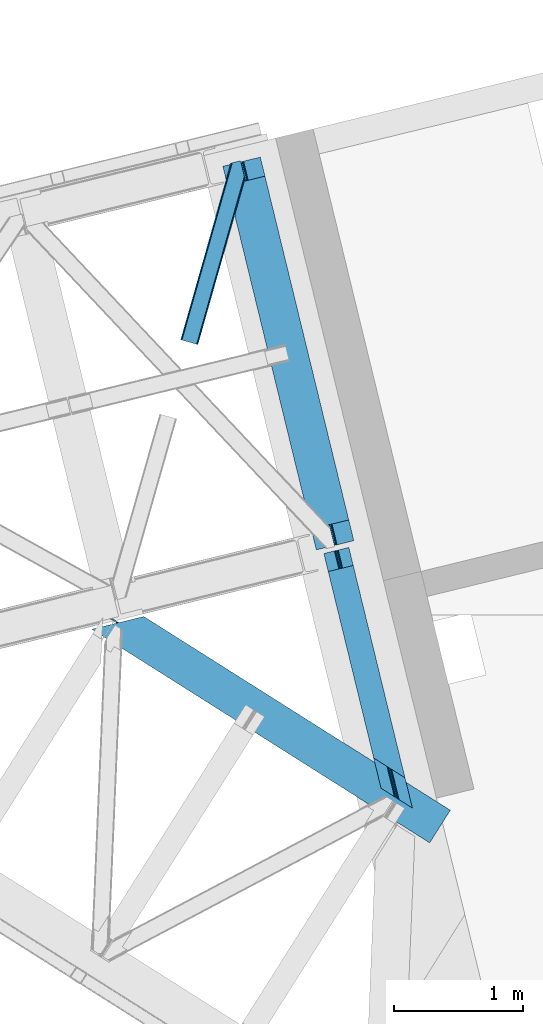
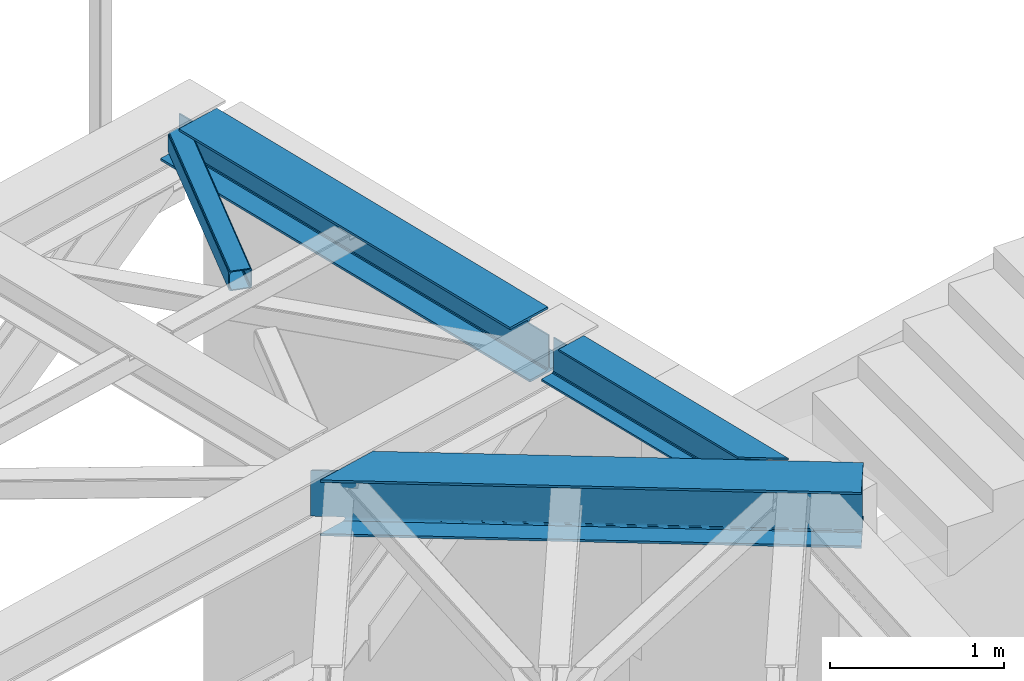
# One storey, part 62 of 67: 3 beams, 1 member.
"""IFC4 building model written with IfcOpenShell, lengths in millimetres."""

from ifc_helpers import new_model, entity, si_unit, converted_unit, derived_unit, direction, frame, origin, place, context, subcontext, project, spatial, triangles, polygons, material, type_object, element, save


model = new_model("IFC4")

# Units and contexts
model_context = context("Model", 3, precision=0.01, world=origin(), true_north=direction((6.12303176911189e-17, 1.0)))
plan_context = context("Plan", 3, precision=0.01, world=origin(), true_north=direction((6.12303176911189e-17, 1.0)))
body_context = subcontext(model_context, "Body", "Model", "MODEL_VIEW")
ifc_project = project(units=[si_unit("LENGTHUNIT", "METRE", prefix="MILLI"), si_unit("AREAUNIT", "SQUARE_METRE"), si_unit("VOLUMEUNIT", "CUBIC_METRE"), converted_unit("PLANEANGLEUNIT", "DEGREE", entity("IfcRatioMeasure", 0.0174532925199433), si_unit("PLANEANGLEUNIT", "RADIAN"), dimensions=[0, 0, 0, 0, 0, 0, 0]), si_unit("MASSUNIT", "GRAM", prefix="KILO"), derived_unit("MASSDENSITYUNIT", [(si_unit("MASSUNIT", "GRAM", prefix="KILO"), 1), (si_unit("LENGTHUNIT", "METRE"), -3)]), derived_unit("MOMENTOFINERTIAUNIT", [(si_unit("LENGTHUNIT", "METRE"), 4)]), si_unit("TIMEUNIT", "SECOND"), si_unit("FREQUENCYUNIT", "HERTZ"), si_unit("THERMODYNAMICTEMPERATUREUNIT", "DEGREE_CELSIUS"), derived_unit("THERMALTRANSMITTANCEUNIT", [(si_unit("MASSUNIT", "GRAM", prefix="KILO"), 1), (si_unit("THERMODYNAMICTEMPERATUREUNIT", "KELVIN"), -1), (si_unit("TIMEUNIT", "SECOND"), -3)]), derived_unit("VOLUMETRICFLOWRATEUNIT", [(si_unit("LENGTHUNIT", "METRE"), 3), (si_unit("TIMEUNIT", "SECOND"), -1)]), derived_unit("MASSFLOWRATEUNIT", [(si_unit("MASSUNIT", "GRAM", prefix="KILO"), 1), (si_unit("TIMEUNIT", "SECOND"), -1)]), derived_unit("ROTATIONALFREQUENCYUNIT", [(si_unit("TIMEUNIT", "SECOND"), -1)]), si_unit("ELECTRICCURRENTUNIT", "AMPERE"), si_unit("ELECTRICVOLTAGEUNIT", "VOLT"), si_unit("POWERUNIT", "WATT"), si_unit("FORCEUNIT", "NEWTON", prefix="KILO"), si_unit("ILLUMINANCEUNIT", "LUX"), si_unit("LUMINOUSFLUXUNIT", "LUMEN"), si_unit("LUMINOUSINTENSITYUNIT", "CANDELA"), derived_unit("USERDEFINED", [(si_unit("MASSUNIT", "GRAM", prefix="KILO"), -1), (si_unit("LENGTHUNIT", "METRE"), -2), (si_unit("TIMEUNIT", "SECOND"), 3), (si_unit("LUMINOUSFLUXUNIT", "LUMEN"), 1)]), derived_unit("LINEARVELOCITYUNIT", [(si_unit("LENGTHUNIT", "METRE"), 1), (si_unit("TIMEUNIT", "SECOND"), -1)]), si_unit("PRESSUREUNIT", "PASCAL"), derived_unit("USERDEFINED", [(si_unit("LENGTHUNIT", "METRE"), -2), (si_unit("MASSUNIT", "GRAM", prefix="KILO"), 1), (si_unit("TIMEUNIT", "SECOND"), -2)]), derived_unit("LINEARFORCEUNIT", [(si_unit("MASSUNIT", "GRAM", prefix="KILO"), 1), (si_unit("LENGTHUNIT", "METRE"), 1), (si_unit("TIMEUNIT", "SECOND"), -2), (si_unit("LENGTHUNIT", "METRE"), -1)]), derived_unit("PLANARFORCEUNIT", [(si_unit("MASSUNIT", "GRAM", prefix="KILO"), 1), (si_unit("LENGTHUNIT", "METRE"), 1), (si_unit("TIMEUNIT", "SECOND"), -2), (si_unit("LENGTHUNIT", "METRE"), -2)])], contexts=[model_context, plan_context])

# Site, building, storey
site_placement = place(None, origin())
site = spatial("IfcSite", under=ifc_project, at=site_placement, CompositionType="ELEMENT")
building_placement = place(site_placement, origin())
building = spatial("IfcBuilding", under=site, at=building_placement, CompositionType="ELEMENT")
storey_placement = place(building_placement, frame((0.0, 0.0, 19800.0)))
storey = spatial("IfcBuildingStorey", under=building, at=storey_placement, CompositionType="ELEMENT", Elevation=19800.0)

# Beams
ifc_material = material(Name="Metal painted (White)")
beam_type_1 = type_object("IfcBeamType", PredefinedType="BEAM")
beam_1_placement = place(storey_placement, frame((-1343.06279661573, 17467.5434466524, 3807.02022389142)))
element("IfcBeam", 1, at=beam_1_placement, inside=storey, type_object=beam_type_1, material=ifc_material, ObjectType="Steel Beam", PredefinedType="BEAM", context=body_context, shape_type="Tessellation", body=[
    polygons([(1018.1664837833, 71.0478278971021, 15.5000000000008), (1018.1664837833, 71.0478278971021, 0.0), (291.465617442453, 3052.25531830422, 0.0), (291.465617442454, 3052.25531830422, 15.5000000000008), (894.779372399333, 40.970914087327, 15.5000000000008), (168.078506058483, 3022.17840449444, 15.5000000000008), (888.087028625381, 39.3395844888265, 16.8701684147984), (161.386162284531, 3020.54707489594, 16.8701684147984), (882.413533524758, 37.9566100336519, 20.7720779386478), (155.712667183908, 3019.16410044076, 20.7720779386478), (878.622625296188, 37.0325360459184, 26.6116982174294), (151.921758955338, 3018.24002645303, 26.6116982174294), (877.291435352788, 36.7080444135029, 33.500000000001), (150.590569011938, 3017.91553482062, 33.500000000001), (140.875048430526, 3015.54727389072, 33.500000000001), (140.875048430528, 3015.54727389072, 259.000000000002), (150.590569011939, 3017.91553482062, 259.000000000002), (2.70716782324598e-13, 2981.20749040711, 0.0), (4.06075173486897e-12, 2981.20749040711, 15.4999999999965), (123.387111383982, 3011.28440421689, 15.5000000000008), (130.079455157932, 3012.91573381539, 16.8701684147898), (135.75295025856, 3014.29870827056, 20.7720779386434), (139.543858487129, 3015.2227822583, 26.6116982174294), (877.291435352789, 36.7080444135072, 259.000000000002), (867.57591477138, 34.3397834836014, 259.000000000002), (867.575914771376, 34.3397834836014, 33.500000000001), (866.244724827979, 34.0152918511859, 26.6116982174294), (862.45381659941, 33.0912178634546, 20.7720779386434), (856.780321498783, 31.70824340828, 16.8701684147898), (850.087977724833, 30.0769138097773, 15.5000000000008), (726.700866340854, 0.0, 15.4999999999965), (726.700866340851, 0.0, 0.0), (838.12452361592, 197.385937999183, 259.069791973884), (186.469722099977, 2870.72539801218, 259.000000000002), (186.693115201829, 2869.8089536072, 259.617303331124), (186.705504045456, 2869.75812937344, 266.500003008253), (837.979344808154, 197.981416001704, 266.500002998871), (837.979694928906, 197.97997969697, 260.000004007589), (828.499586345894, 194.645865944436, 259.006343171919), (828.276216326131, 195.562317481916, 259.617303331124), (828.263827482503, 195.613141715691, 266.500003008253), (176.989986719805, 2867.38985508743, 266.500002998871), (176.989636599053, 2867.39129139216, 260.000004007589), (176.844830940719, 2867.98534020595, 259.07612046749), (176.75420151856, 2868.35713708228, 259.000000000002), (839.310832678077, 198.30468544639, 273.388305639783), (843.101109266768, 199.231350618303, 279.227924098781), (848.774180214308, 200.616065081983, 283.129832400619), (855.466371895431, 202.248018612794, 284.500000377224), (978.853400583272, 232.325271667905, 284.500000138971), (978.851730776624, 232.332121736639, 299.999995328161), (687.386308679348, 161.283492472596, 299.999995890962), (687.387978486002, 161.276642403861, 284.500000701776), (810.775007173859, 191.353895458976, 284.500000463519), (817.467494069994, 192.984637925553, 283.129832461069), (823.141405718764, 194.365903570081, 279.227924137322), (826.932940505748, 195.287407219375, 273.388305663684), (175.658498849865, 2867.06658564273, 273.388305639783), (171.86822226118, 2866.13992047083, 279.227924098781), (166.195151313635, 2864.75520600714, 283.129832400619), (159.502959632511, 2863.12325247633, 284.500000377228), (36.1159309446587, 2833.04599942122, 284.500000138971), (36.1176007513048, 2833.03914935249, 299.999995328161), (327.583022848581, 2904.08777861653, 299.999995890962), (327.581353041929, 2904.09462868526, 284.500000701776), (204.194324354082, 2874.01737563015, 284.500000463519), (197.501837457949, 2872.38663316357, 283.129832461069), (191.827925809184, 2871.00536751905, 279.227924137318), (188.036391022195, 2870.08386386975, 273.388305663684)], [[[1, 2, 3, 4]], [[5, 1, 4, 6]], [[7, 5, 6, 8]], [[9, 7, 8, 10]], [[11, 9, 10, 12]], [[13, 11, 12, 14]], [[15, 16, 17, 14, 12, 10, 8, 6, 4, 3, 18, 19, 20, 21, 22, 23]], [[13, 24, 25, 26, 27, 28, 29, 30, 31, 32, 2, 1, 5, 7, 9, 11]], [[2, 32, 18, 3]], [[32, 31, 19, 18]], [[31, 30, 20, 19]], [[27, 26, 15, 23]], [[28, 27, 23, 22]], [[29, 28, 22, 21]], [[30, 29, 21, 20]], [[33, 24, 13, 14, 17, 34, 35, 36, 37, 38]], [[25, 39, 40, 41, 42, 43, 44, 16, 15, 26]], [[39, 25, 24, 33]], [[45, 34, 17, 16]], [[41, 40, 38, 37, 46, 47, 48, 49, 50, 51, 52, 53, 54, 55, 56, 57]], [[42, 58, 59, 60, 61, 62, 63, 64, 65, 66, 67, 68, 69, 36, 35, 43]], [[46, 37, 36, 69]], [[47, 46, 69, 68]], [[48, 47, 68, 67]], [[49, 48, 67, 66]], [[50, 49, 66, 65]], [[51, 50, 65, 64]], [[52, 51, 64, 63]], [[53, 52, 63, 62]], [[54, 53, 62, 61]], [[55, 54, 61, 60]], [[56, 55, 60, 59]], [[57, 56, 59, 58]], [[41, 57, 58, 42]]], closed=False),
])
beam_2_placement = place(storey_placement, frame((-557.956044508696, 15460.6609407548, 3813.0)))
element("IfcBeam", 2, at=beam_2_placement, inside=storey, type_object=beam_type_1, material=ifc_material, ObjectType="Steel Beam", PredefinedType="BEAM", context=body_context, shape_type="Tessellation", body=[
    polygons([(503.901998279631, 315.50898790348, 264.000000000001), (502.234787414298, 316.562983810857, 270.888301782572), (125.857083537508, 1860.60962251877, 270.888301782572), (127.188273480905, 1860.93411415118, 264.000000000001), (497.486972559246, 319.564510210594, 276.727922061363), (122.066175308936, 1859.68554853103, 276.727922061363), (490.381365487108, 324.056611917234, 280.629831585203), (116.392680208322, 1858.30257407586, 280.629831585203), (481.999730462124, 329.355407166941, 282.000000000001), (109.700336434367, 1856.67124447736, 282.000000000001), (387.394101417021, 389.164245929956, 282.000000000001), (34.1621639138618, 1838.25801574736, 282.000000000001), (387.394101417016, 389.164245929958, 294.999999999994), (34.1621639138565, 1838.25801574736, 294.999999999994), (135.446465975099, 1862.9471359416, 258.999999999997), (127.188273480905, 1860.93411415118, 258.999999999997), (228.472575542141, 1885.62323434542, 294.999999999998), (228.472575542145, 1885.62323434542, 281.999999999997), (152.934403021655, 1867.21000561543, 282.000000000001), (146.24205924769, 1865.57867601692, 280.629831585203), (140.56856414708, 1864.19570156175, 276.727922061358), (136.777655918495, 1863.27162757401, 270.888301782572), (135.4464659751, 1862.9471359416, 264.000000000001), (514.244735860121, 308.970401029069, 255.000000000003), (514.244735860121, 308.970401029069, 264.000000000001), (515.911946725451, 307.916405121688, 270.888301782572), (520.659761580513, 304.914878721951, 276.727922061358), (527.76536865265, 300.422777015311, 280.629831585203), (536.14700367764, 295.123981765602, 282.000000000001), (630.752632722732, 235.31514300259, 281.999999999997), (630.752632722729, 235.31514300259, 294.999999999998), (503.901998279631, 315.50898790348, 255.000000000003), (93.0261095670512, 2001.08049853809, 258.999999999997), (93.0261095670512, 2001.08049853809, 30.9999999999973), (561.262553971507, 80.1938449016465, 30.9999999999973), (561.262553971513, 80.1938449016551, 253.999999999999), (504.242922830551, 314.110383784594, 253.999999999999), (101.284302061246, 2003.09352032851, 30.9999999999973), (101.284302061246, 2003.09352032851, 258.999999999997), (514.58566041104, 307.571796910181, 253.999999999999), (571.605291551999, 73.65525802724, 253.999999999999), (571.605291551993, 73.6552580272313, 30.9999999999973), (444.754657108931, 153.849102928183, 0.0), (688.113188415015, 1.99247551790904e-10, 0.0), (688.113188415522, 4.98118879477261e-11, 13.0000000000014), (593.507559369495, 59.8088387637354, 13.0000000000014), (585.125924344507, 65.1076340134534, 14.370168414799), (578.020317272372, 69.5997357200954, 18.2720779386353), (573.272502417317, 72.6012621198371, 24.11169821743), (559.595343106168, 81.2478408090147, 24.1116982174213), (554.847528251111, 84.2493672087563, 18.2720779386353), (547.741921178978, 88.7414689153962, 14.3701684147947), (539.360286153997, 94.0402641651099, 13.0000000000014), (444.754657108934, 153.849102928187, 13.0000000000014), (102.615492004642, 2003.41801196092, 24.1116982174213), (106.406400233223, 2004.34208594866, 18.2720779386353), (112.079895333836, 2005.72506040383, 14.370168414799), (118.7722391078, 2007.35639000234, 13.0000000000014), (194.310411628288, 2025.76961873233, 13.0000000000014), (194.310411628358, 2025.76961873235, 0.0), (7.44471151392645e-13, 1978.40440013427, 0.0), (3.65467656138208e-12, 1978.40440013427, 13.0000000000014), (75.5381725205065, 1996.81762886426, 13.0000000000014), (82.2305162944635, 1998.44895846277, 14.3701684147947), (87.9040113950731, 1999.83193291794, 18.2720779386353), (91.6949196236502, 2000.75600690567, 24.1116982174213)], [[[1, 2, 3, 4]], [[2, 5, 6, 3]], [[5, 7, 8, 6]], [[7, 9, 10, 8]], [[11, 12, 10, 9]], [[13, 14, 12, 11]], [[15, 16, 4, 3, 6, 8, 10, 12, 14, 17, 18, 19, 20, 21, 22, 23]], [[24, 25, 26, 27, 28, 29, 30, 31, 13, 11, 9, 7, 5, 2, 1, 32]], [[31, 17, 14, 13]], [[30, 18, 17, 31]], [[29, 19, 18, 30]], [[29, 28, 20, 19]], [[28, 27, 21, 20]], [[27, 26, 22, 21]], [[26, 25, 23, 22]], [[4, 16, 33, 34, 35, 36, 37, 32, 1]], [[38, 39, 15, 23, 25, 24, 40, 41, 42]], [[39, 33, 16, 15]], [[41, 40, 37, 36]], [[43, 44, 45, 46, 47, 48, 49, 42, 41, 36, 35, 50, 51, 52, 53, 54]], [[39, 38, 55, 56, 57, 58, 59, 60, 61, 62, 63, 64, 65, 66, 34, 33]], [[42, 49, 55, 38]], [[49, 48, 56, 55]], [[48, 47, 57, 56]], [[47, 46, 58, 57]], [[46, 45, 59, 58]], [[60, 59, 45, 44]], [[53, 52, 64, 63]], [[52, 51, 65, 64]], [[51, 50, 66, 65]], [[50, 35, 34, 66]], [[54, 53, 63, 62]], [[43, 54, 62, 61]], [[44, 43, 61, 60]]], closed=False),
])
beam_type_2 = type_object("IfcBeamType", PredefinedType="BEAM")
beam_3_placement = place(storey_placement, frame((-2362.11831893921, 15190.2832672119, 3715.9994934082)))
element("IfcBeam", 3, at=beam_3_placement, inside=storey, type_object=beam_type_2, ObjectType="Steel Beam", PredefinedType="BEAM", context=body_context, shape_type="Tessellation", body=[
    triangles([(25.3249076843263, 1815.17176208496, 36.0001281738296), (40.9816555023194, 1818.98780822754, 36.0001281738296), (181.779747390747, 1716.15803833008, 36.0001281738296), (197.558580780029, 1720.00431518555, 36.0001281738296), (207.42120552063, 1714.40233154297, 32.7793945312515), (211.844627380371, 1713.10473632813, 29.1912414550789), (191.366516876221, 1708.03411560059, 29.2098449707046), (190.191879272461, 1710.20258789062, 32.7793945312515), (189.084098052978, 1706.61559753418, 25.0007995605483), (216.100762939453, 1713.20124206543, 25.0007995605483), (202.62673072815, 1716.90682983398, 35.1629699707046), (186.599365997315, 1713.00009155273, 35.1629699707046), (2710.74209747314, 133.063970947265, 29.5819152832046), (2713.28772697449, 137.095120239257, 22.4451416015654), (219.060320663452, 1713.92329101562, 22.4451416015654), (2709.84731197357, 131.648941040039, 38.0000061035171), (40.8597152709963, 1818.95874023438, 38.0000061035171), (2717.10202903748, 143.127310180664, 17.6756652832046), (228.703046035766, 1716.27314758301, 17.6756652832046), (2721.60019197464, 150.244317626953, 16.0013488769546), (240.071683502197, 1719.04507141113, 16.0013488769546), (405.184860992432, 1759.29261474609, 16.0013488769546), (2786.92556505203, 253.576382446288, 16.0013488769546), (2786.92556505203, 253.576382446288, 0.0), (405.184860992432, 1759.29261474609, 0.0), (0.0, 1660.52422485351, 0.0), (2626.6178355217, 0.0, 0.0), (165.113177490234, 1700.7729309082, 16.0013488769546), (0.0, 1660.52422485351, 16.0013488769546), (176.486320495605, 1703.54485473633, 17.6756652832046), (186.124540328979, 1705.89471130371, 22.4451416015654), (2626.6178355217, 0.0, 16.0013488769546), (2691.94328126907, 103.332064819337, 16.0013488769546), (2703.70066680908, 121.928604125977, 38.0000061035171), (25.3249076843263, 1815.17176208496, 38.0000061035171), (2702.80588130951, 120.512411499023, 29.5819152832046), (2700.25570993423, 116.481262207031, 22.4451416015654), (2696.44137153625, 110.447909545899, 17.6756652832046), (2709.84731197357, 131.648941040039, 354.001647949219), (40.8597152709963, 1818.95874023438, 354.001647949219), (2703.70066680908, 121.928604125977, 354.001647949219), (25.3249076843263, 1815.17176208496, 354.001647949219), (25.2766548156737, 1815.09502258301, 356.001525878906), (40.9816555023194, 1818.98780822754, 356.001525878906), (181.779747390747, 1716.15803833008, 356.001525878906), (197.558580780029, 1720.00431518555, 356.001525878906), (202.62673072815, 1716.90682983398, 356.838684082031), (186.599365997315, 1713.00009155273, 356.838684082031), (207.42120552063, 1714.40233154297, 359.222259521484), (190.191879272461, 1710.20258789062, 359.222259521484), (211.849278259278, 1713.02683410644, 362.791809082031), (191.366516876221, 1708.03411560059, 362.791809082031), (216.100762939453, 1713.20124206543, 367.000854492188), (189.084098052978, 1706.61559753418, 367.000854492188), (2710.74209747314, 133.063970947265, 362.419738769531), (2713.28772697449, 137.095120239257, 369.556512451174), (219.060320663452, 1713.92329101562, 369.556512451174), (2721.60019197464, 150.244317626953, 376.000305175781), (2717.10202903748, 143.127310180664, 374.325988769531), (240.071683502197, 1719.04507141113, 376.000305175781), (228.703046035766, 1716.27314758301, 374.325988769531), (2702.80588130951, 120.512411499023, 362.419738769531), (2700.25570993423, 116.481262207031, 369.556512451174), (186.124540328979, 1705.89471130371, 369.556512451174), (2696.44137153625, 110.447909545899, 374.325988769531), (176.486320495605, 1703.54485473633, 374.325988769531), (2691.94328126907, 103.332064819337, 376.000305175781), (165.113177490234, 1700.7729309082, 376.000305175781), (405.184860992432, 1759.29261474609, 376.000305175781), (2786.92556505203, 253.576382446288, 376.000305175781), (2786.92556505203, 253.576382446288, 392.001654052736), (405.184860992432, 1759.29261474609, 392.001654052736), (2626.6178355217, 0.0, 392.001654052736), (2626.6178355217, 0.0, 376.000305175781), (0.0, 1660.52422485351, 392.001654052736), (0.0, 1660.52422485351, 376.000305175781)], [[1, 2, 3], [4, 3, 2], [5, 6, 7], [7, 8, 5], [9, 7, 6], [6, 10, 9], [11, 5, 8], [8, 12, 11], [4, 11, 12], [12, 3, 4], [13, 14, 15], [15, 10, 13], [16, 11, 4], [4, 17, 16], [4, 2, 17], [16, 13, 6], [6, 5, 16], [5, 11, 16], [10, 6, 13], [14, 18, 19], [19, 15, 14], [18, 20, 21], [21, 19, 18], [22, 21, 20], [20, 23, 22], [23, 24, 25], [25, 22, 23], [26, 25, 27], [24, 27, 25], [26, 28, 21], [29, 28, 26], [21, 28, 19], [21, 25, 26], [22, 25, 21], [19, 28, 30], [30, 31, 15], [31, 9, 10], [10, 15, 31], [15, 19, 30], [28, 29, 32], [32, 33, 28], [27, 32, 26], [29, 26, 32], [34, 35, 3], [3, 36, 34], [3, 12, 36], [35, 1, 3], [12, 8, 36], [8, 7, 36], [37, 7, 9], [7, 37, 36], [9, 31, 37], [33, 38, 30], [30, 28, 33], [38, 37, 31], [31, 30, 38], [39, 16, 17], [17, 40, 39], [34, 41, 35], [42, 35, 41], [40, 42, 17], [43, 42, 40], [40, 44, 43], [17, 42, 35], [35, 1, 17], [2, 17, 1], [44, 43, 45], [45, 46, 44], [47, 46, 48], [45, 48, 46], [49, 47, 50], [48, 50, 47], [51, 49, 52], [50, 52, 49], [53, 51, 54], [52, 54, 51], [55, 47, 49], [39, 40, 46], [46, 55, 39], [46, 47, 55], [40, 44, 46], [49, 51, 55], [56, 51, 53], [51, 56, 55], [53, 57, 56], [58, 59, 60], [61, 60, 59], [59, 56, 61], [57, 61, 56], [41, 48, 45], [41, 50, 48], [45, 42, 41], [45, 43, 42], [41, 62, 52], [52, 50, 41], [63, 64, 54], [54, 62, 63], [54, 52, 62], [63, 65, 64], [66, 64, 65], [65, 67, 66], [68, 66, 67], [60, 69, 58], [70, 58, 69], [71, 70, 69], [69, 72, 71], [16, 39, 41], [56, 59, 65], [58, 71, 73], [70, 71, 58], [59, 58, 67], [39, 55, 62], [55, 56, 63], [14, 38, 18], [24, 20, 27], [20, 18, 33], [24, 23, 20], [14, 13, 37], [13, 16, 36], [34, 16, 41], [67, 65, 59], [62, 55, 63], [65, 63, 56], [62, 41, 39], [73, 67, 58], [73, 74, 67], [33, 18, 38], [37, 13, 36], [34, 36, 16], [37, 38, 14], [33, 27, 20], [27, 33, 32], [61, 66, 68], [54, 64, 53], [64, 66, 57], [61, 57, 66], [57, 53, 64], [68, 75, 60], [75, 68, 76], [72, 60, 75], [68, 60, 61], [72, 69, 60], [72, 75, 73], [73, 71, 72], [74, 73, 76], [75, 76, 73], [76, 68, 74], [67, 74, 68]]),
])

# Member
member_type = type_object("IfcMemberType", PredefinedType="BRACE")
member_placement = place(storey_placement, frame((-1671.07256355286, 19062.4736572266, 3823.02086791992)))
element("IfcMember", 4, at=member_placement, inside=storey, type_object=member_type, ObjectType="Steel Horizontal Brace", PredefinedType="BRACE", context=body_context, shape_type="Tessellation", body=[
    triangles([(500.301584243774, 1287.51443481445, 17.4989318847656), (500.301584243774, 1287.51443481445, 122.499499511716), (134.676372528076, 0.0, 17.4989318847656), (134.676372528076, 0.0, 122.499499511716), (495.114400863647, 1308.79453125, 138.668280029295), (491.898754119873, 1321.98674926758, 139.998431396481), (117.842952346802, 4.77994079589553, 139.998431396481), (124.282530212402, 2.94981994628688, 138.668280029295), (497.840469932556, 1297.61149291992, 134.873162841795), (129.74440612793, 1.39991455078052, 134.873162841795), (499.662015724182, 1290.13985595703, 129.196765136716), (133.395636749268, 0.363931274412607, 129.196765136716), (16.8379257202148, 33.4642364501924, 139.998431396481), (409.260048294067, 1415.34616699219, 139.998431396481), (465.782761001587, 1429.12439575195, 139.998431396481), (391.19923210144, 1410.94411010742, 129.196765136716), (389.71269493103, 1410.58134155273, 122.499499511716), (1.28073577880855, 37.880245971679, 129.196765136716), (0.0, 38.2441772460916, 122.499499511716), (395.437636184692, 1411.97660522461, 134.873162841795), (4.93196640014662, 36.844262695311, 134.873162841795), (401.777220153809, 1413.52302246094, 138.668280029295), (10.393842315674, 35.2931945800774, 138.668280029295), (389.71269493103, 1410.58134155273, 17.4989318847656), (0.0, 38.2441772460916, 17.4989318847656), (1.28073577880855, 37.880245971679, 10.8016662597656), (391.19923210144, 1410.94411010742, 10.8016662597656), (350.625400543213, 1255.50010986328, 5.49966430664063), (4.93196640014662, 36.844262695311, 5.12526855468604), (350.610866546631, 1254.51877441406, 5.25084228515334), (395.030974960327, 1411.87893676758, 5.49966430664063), (350.591681671143, 1253.51883544922, 4.99969482421875), (10.393842315674, 35.2931945800774, 1.33247680663771), (350.577002334595, 1252.51657104492, 4.74622192382594), (350.562613677979, 1251.53756103515, 4.49972534179688), (352.972204971313, 1241.65211791992, 1.33247680663771), (356.187851715088, 1228.45989990234, 0.0), (16.8379257202148, 33.4642364501924, 0.0), (386.342987823486, 1104.751171875, 0.0), (117.842952346802, 4.77994079589553, 0.0), (433.47165184021, 1116.23884277344, 0.0), (447.69621963501, 1119.70607299804, 5.49966430664063), (440.949974441528, 1118.06198730469, 1.33247680663771), (387.314440155029, 1104.98836669922, 5.49966430664063), (386.342987823486, 1104.751171875, 4.49972534179688), (498.721520805359, 1286.82843017578, 10.8016662597656), (133.395636749268, 0.363931274412607, 10.8016662597656), (129.74440612793, 1.39991455078052, 5.12526855468604), (124.282530212402, 2.94981994628688, 1.33247680663771), (494.138297653198, 1283.24260253906, 5.49966430664063), (499.951314926147, 1288.95155639648, 12.4992370605469), (458.982304000855, 1427.46635742187, 5.49966430664063), (494.653818511963, 1310.68511352539, 12.4992370605469), (489.445488166809, 1314.45465087891, 8.33204956054396), (485.489479637146, 1325.04702758789, 6.99957275390625), (460.437302398682, 1427.8221496582, 6.99957275390625), (23.5703636169435, 31.5515624999971, 6.99957275390625), (417.077158355713, 1417.2507019043, 6.99957275390625), (111.110514450073, 6.69261474609084, 6.99957275390625), (496.300883674622, 1303.92738647461, 17.8035644531228), (123.011968231201, 3.31258850097583, 12.1248413085923), (126.663198852539, 2.27660522460792, 17.8035644531228), (496.940452194214, 1301.30429077148, 24.4985046386719), (127.943934631348, 1.91151123046802, 24.4985046386719), (117.550092315674, 4.86249389648219, 8.33204956054396), (496.940452194214, 1301.30429077148, 115.49992675781), (127.943934631348, 1.91151123046802, 115.49992675781), (496.300883674622, 1303.92738647461, 122.19719238281), (494.479337882996, 1311.3990234375, 127.873590087889), (491.75334148407, 1322.58206176758, 131.666381835938), (488.537622070313, 1335.77427978515, 132.998858642575), (465.782761001587, 1429.12439575195, 132.998858642575), (126.663198852539, 2.27660522460792, 122.19719238281), (123.011968231201, 3.31258850097583, 127.873590087889), (117.550092315674, 4.86249389648219, 131.666381835938), (111.110514450073, 6.69261474609084, 132.998858642575), (23.5703636169435, 31.5515624999971, 132.998858642575), (417.077158355713, 1417.2507019043, 132.998858642575), (11.6645496368408, 34.9315887451157, 127.873590087889), (17.1264255523681, 33.3805206298821, 131.666381835938), (6.73694343566899, 36.3326660156235, 115.49992675781), (8.01767921447754, 35.9687347412109, 122.19719238281), (11.6645496368408, 34.9315887451157, 12.1248413085923), (17.1264255523681, 33.3805206298821, 8.33204956054396), (6.73694343566899, 36.3326660156235, 24.4985046386719), (8.01767921447754, 35.9687347412109, 17.8035644531228), (409.598835754394, 1415.4298828125, 131.666381835938), (403.254746246338, 1413.88346557617, 127.873590087889), (399.020847702026, 1412.85097045898, 122.19719238281), (397.529804992676, 1412.48587646484, 115.49992675781), (409.598835754394, 1415.4298828125, 8.33204956054396), (399.020847702026, 1412.85097045898, 17.8035644531228), (403.254746246338, 1413.88346557617, 12.1248413085923), (397.529804992676, 1412.48587646484, 24.4985046386719)], [[1, 2, 3], [4, 3, 2], [5, 6, 7], [7, 8, 5], [9, 5, 8], [8, 10, 9], [11, 9, 10], [10, 12, 11], [2, 11, 12], [12, 4, 2], [13, 6, 14], [13, 7, 6], [6, 15, 14], [16, 17, 18], [19, 18, 17], [20, 16, 21], [18, 21, 16], [22, 20, 23], [21, 23, 20], [14, 22, 13], [23, 13, 22], [17, 24, 19], [25, 19, 24], [26, 27, 28], [28, 29, 26], [28, 30, 29], [27, 31, 28], [32, 33, 29], [32, 34, 33], [35, 33, 34], [35, 36, 33], [36, 37, 33], [38, 33, 37], [24, 27, 26], [26, 25, 24], [39, 38, 37], [40, 39, 41], [39, 40, 38], [41, 42, 43], [41, 39, 44], [41, 44, 42], [44, 39, 45], [30, 28, 44], [34, 32, 44], [35, 34, 45], [37, 35, 45], [37, 36, 35], [45, 39, 37], [46, 1, 3], [3, 47, 46], [48, 49, 43], [47, 48, 42], [50, 46, 42], [47, 42, 46], [43, 42, 48], [41, 43, 49], [49, 40, 41], [46, 51, 1], [42, 28, 50], [42, 44, 28], [31, 50, 28], [52, 50, 31], [53, 50, 54], [51, 46, 53], [53, 46, 50], [55, 50, 52], [50, 55, 54], [52, 56, 55], [57, 55, 58], [57, 59, 55], [55, 56, 58], [60, 53, 61], [61, 62, 60], [63, 60, 62], [62, 64, 63], [54, 55, 59], [59, 65, 54], [53, 54, 65], [65, 61, 53], [66, 63, 67], [64, 67, 63], [60, 51, 53], [2, 1, 63], [1, 60, 63], [63, 66, 2], [1, 51, 60], [68, 2, 66], [11, 2, 68], [9, 68, 69], [68, 9, 11], [69, 5, 9], [70, 5, 69], [70, 71, 6], [70, 6, 5], [71, 15, 6], [71, 72, 15], [68, 66, 73], [67, 73, 66], [69, 68, 74], [73, 74, 68], [70, 69, 75], [74, 75, 69], [71, 70, 76], [75, 76, 70], [77, 71, 76], [71, 77, 78], [72, 71, 78], [12, 74, 73], [67, 3, 4], [12, 73, 4], [12, 10, 74], [73, 67, 4], [74, 10, 8], [76, 7, 13], [7, 75, 8], [75, 7, 76], [75, 74, 8], [47, 61, 48], [64, 3, 67], [3, 62, 47], [62, 3, 64], [47, 62, 61], [40, 59, 38], [49, 48, 61], [61, 65, 49], [65, 59, 40], [40, 49, 65], [79, 23, 21], [13, 77, 76], [13, 80, 77], [80, 13, 23], [79, 80, 23], [81, 19, 25], [18, 82, 79], [21, 18, 79], [82, 18, 19], [81, 82, 19], [33, 83, 29], [38, 59, 57], [57, 84, 38], [84, 83, 33], [33, 38, 84], [26, 29, 83], [25, 85, 81], [86, 25, 26], [25, 86, 85], [86, 26, 83], [22, 14, 87], [15, 78, 14], [78, 15, 72], [78, 87, 14], [88, 22, 87], [88, 20, 22], [16, 88, 89], [88, 16, 20], [17, 89, 90], [89, 17, 16], [58, 31, 91], [92, 93, 27], [93, 91, 31], [58, 52, 31], [52, 58, 56], [94, 92, 24], [27, 24, 92], [17, 94, 24], [94, 17, 90], [93, 31, 27], [87, 78, 77], [77, 80, 87], [88, 87, 80], [80, 79, 88], [89, 88, 79], [79, 82, 89], [90, 89, 82], [82, 81, 90], [94, 90, 85], [81, 85, 90], [92, 94, 86], [85, 86, 94], [93, 92, 83], [86, 83, 92], [91, 93, 84], [83, 84, 93], [58, 91, 57], [84, 57, 91]]),
])

save(model, "model.ifc")
